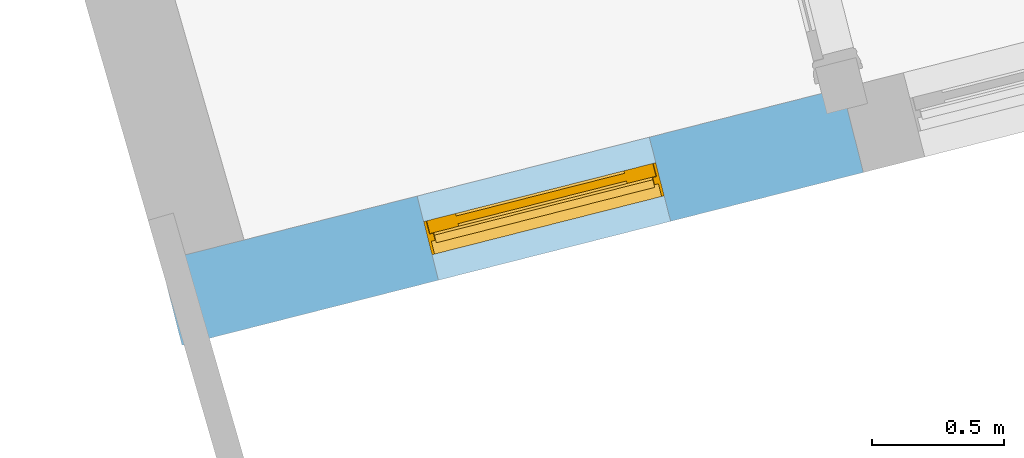
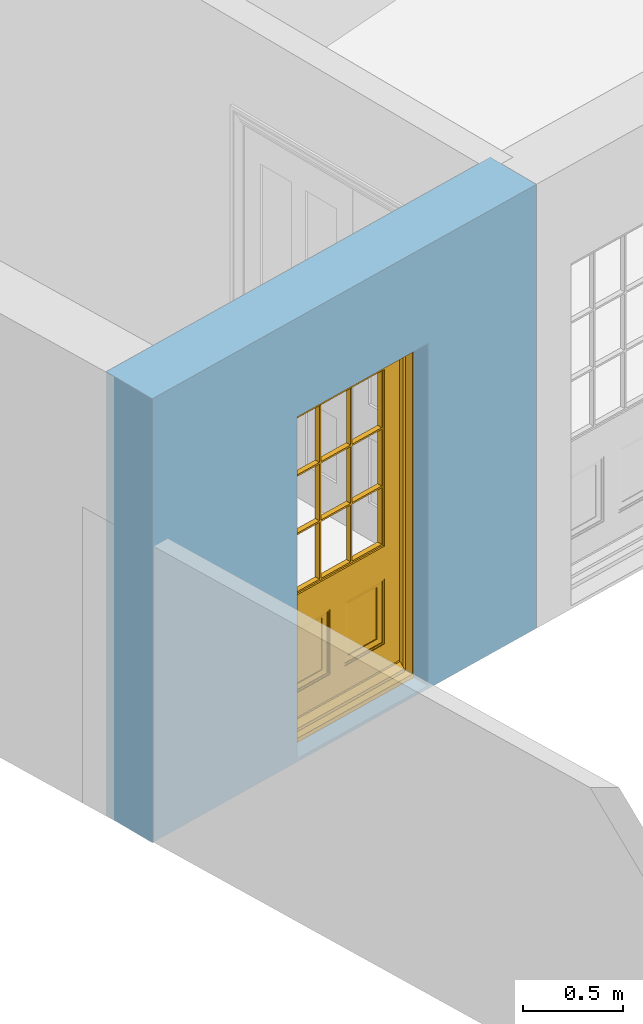
# One storey, part 2 of 15: 1 door, 1 opening, plus 1 element that does not belong to this part.
"""IFC2X3 building model written with IfcOpenShell, lengths in metres."""

import ifcopenshell
import ifcopenshell.guid

model = None  # the IFC model being written
_history = None  # IfcOwnerHistory: only IFC2X3 demands one
_inside = {}  # id of a spatial element -> (the spatial element, [elements in it])
_under = {}  # id of a project, library or spatial element -> (it, [spatial elements below it])
_declared = {}  # id of a project -> (the project, [libraries it declares])
_typed = {}  # id of a type object -> (the type object, [elements of that type])
_made_of = {}  # id of a material, layer set ... -> (it, [elements and type objects made of it])


def new_model(schema):
    """Start an empty IFC model of exactly this schema.

    Asked for "IFC4X3", IfcOpenShell would pick the latest addendum, in which some entities
    have other attributes; the version numbers below select the first issue.
    IFC2X3 requires an IfcOwnerHistory on every rooted entity: one is made here for all.
    """
    global model, _history
    if schema == "IFC4X3":
        model = ifcopenshell.file(schema_version=(4, 3, 0, 0))
    else:
        model = ifcopenshell.file(schema=schema)
    _inside.clear()
    _under.clear()
    _declared.clear()
    _typed.clear()
    _made_of.clear()
    _history = None
    if model.schema == "IFC2X3":
        org = make("IfcOrganization", Name="unknown")
        user = make(
            "IfcPersonAndOrganization",
            ThePerson=make("IfcPerson", FamilyName="unknown"),
            TheOrganization=org,
        )
        app = make(
            "IfcApplication",
            ApplicationDeveloper=org,
            Version="unknown",
            ApplicationFullName="unknown",
            ApplicationIdentifier="unknown",
        )
        _history = make(
            "IfcOwnerHistory",
            OwningUser=user,
            OwningApplication=app,
            ChangeAction="ADDED",
            CreationDate=0,
        )
    return model


def make(cls, **values):
    """One entity of the class cls with the attributes given. An attribute that is None is left unset."""
    return model.create_entity(
        cls, **{name: value for name, value in values.items() if value is not None}
    )


def rooted(cls, **values):
    """An entity with a GlobalId (a new one), such as an element, a storey or a relation."""
    return make(cls, GlobalId=ifcopenshell.guid.new(), OwnerHistory=_history, **values)


def si_unit(unit_type, name, prefix=None):
    """IfcSIUnit, for example si_unit("LENGTHUNIT", "METRE", prefix="MILLI")."""
    return make("IfcSIUnit", UnitType=unit_type, Prefix=prefix, Name=name)


def assignment(units):
    """IfcUnitAssignment: the units of a project."""
    return None if units is None else make("IfcUnitAssignment", Units=units)


def point(xyz):
    """IfcCartesianPoint."""
    return None if xyz is None else make("IfcCartesianPoint", Coordinates=xyz)


def direction(xyz):
    """IfcDirection."""
    return None if xyz is None else make("IfcDirection", DirectionRatios=xyz)


def frame(location, z_axis=None, x_axis=None):
    """IfcAxis2Placement3D, a coordinate frame: its origin and axes. An axis left out is left unset."""
    return make(
        "IfcAxis2Placement3D",
        Location=point(location),
        Axis=direction(z_axis),
        RefDirection=direction(x_axis),
    )


def origin():
    """The frame at (0, 0, 0) with its axes left unset."""
    return frame((0.0, 0.0, 0.0))


def place(relative_to, where):
    """IfcLocalPlacement: puts the frame where relative to a parent placement (None: the world)."""
    return make(
        "IfcLocalPlacement", PlacementRelTo=relative_to, RelativePlacement=where
    )


def context(
    kind, dimensions, precision=None, world=None, true_north=None, identifier=None
):
    """IfcGeometricRepresentationContext, for example the 3D "Model" context."""
    return make(
        "IfcGeometricRepresentationContext",
        ContextIdentifier=identifier,
        ContextType=kind,
        CoordinateSpaceDimension=dimensions,
        Precision=precision,
        WorldCoordinateSystem=world,
        TrueNorth=true_north,
    )


def subcontext(parent, identifier, kind, view, scale=None):
    """IfcGeometricRepresentationSubContext, for example "Body" below "Model"."""
    return make(
        "IfcGeometricRepresentationSubContext",
        ContextIdentifier=identifier,
        ContextType=kind,
        ParentContext=parent,
        TargetScale=scale,
        TargetView=view,
    )


def project(units=None, contexts=None):
    """IfcProject with its units and contexts."""
    return rooted(
        "IfcProject",
        Name="project",
        RepresentationContexts=contexts,
        UnitsInContext=assignment(units),
    )


def spatial(cls, under=None, at=None, **own):
    """A site, building, storey or space (cls), placed at a placement, below another one or the project."""
    s = rooted(cls, ObjectPlacement=at, **own)
    if under is not None:
        _under.setdefault(under.id(), (under, []))[1].append(s)
    return s


def polyline(points):
    """IfcPolyline through the points."""
    return make("IfcPolyline", Points=[point(p) for p in points])


def outline(outer, holes=None, kind="AREA"):
    """IfcArbitraryClosedProfileDef: a profile drawn as a closed curve; with holes, ...WithVoids."""
    if holes is None:
        return make("IfcArbitraryClosedProfileDef", ProfileType=kind, OuterCurve=outer)
    return make(
        "IfcArbitraryProfileDefWithVoids",
        ProfileType=kind,
        OuterCurve=outer,
        InnerCurves=holes,
    )


def extrude(swept, where, along, depth):
    """IfcExtrudedAreaSolid: the profile swept, set in the frame where, extruded along a direction by depth."""
    return make(
        "IfcExtrudedAreaSolid",
        SweptArea=swept,
        Position=where,
        ExtrudedDirection=direction(along),
        Depth=depth,
    )


def faces_of(points, faces, orient=None, outer=None):
    """IfcFace entities. A face is a list of loops; a loop is a list of indices into points, from 0.

    orient and outer hold one flag for each loop. By default every Orientation is true, the
    first loop of a face is its IfcFaceOuterBound and the others are IfcFaceBound.
    """
    made = []
    for i, loops in enumerate(faces):
        bounds = []
        for j, loop in enumerate(loops):
            is_outer = j == 0 if outer is None else outer[i][j]
            bounds.append(
                make(
                    "IfcFaceOuterBound" if is_outer else "IfcFaceBound",
                    Bound=make("IfcPolyLoop", Polygon=[points[k] for k in loop]),
                    Orientation=True if orient is None else orient[i][j],
                )
            )
        made.append(make("IfcFace", Bounds=bounds))
    return made


def faceted_brep(points, faces, orient=None, outer=None, voids=None):
    """IfcFacetedBrep: a solid bounded by flat faces; with voids (closed shells), ...WithVoids."""
    shared = [point(p) for p in points]
    hull = make("IfcClosedShell", CfsFaces=faces_of(shared, faces, orient, outer))
    if voids is None:
        return make("IfcFacetedBrep", Outer=hull)
    return make(
        "IfcFacetedBrepWithVoids",
        Outer=hull,
        Voids=[
            make(cls, CfsFaces=faces_of(shared, fs, o, b)) for cls, fs, o, b in voids
        ],
    )


def shape(context_of_items, identifier, shape_type, items):
    """IfcShapeRepresentation: the items that make up one representation, for example the "Body"."""
    return make(
        "IfcShapeRepresentation",
        ContextOfItems=context_of_items,
        RepresentationIdentifier=identifier,
        RepresentationType=shape_type,
        Items=items,
    )


def material(Name=None, Category=None):
    """IfcMaterial."""
    return make("IfcMaterial", Name=Name, Category=Category)


def layer(
    of_material, thickness, ventilated=None, Name=None, Category=None, Priority=None
):
    """IfcMaterialLayer: one layer of a wall or slab, of a material (None: an air gap)."""
    return make(
        "IfcMaterialLayer",
        Material=of_material,
        LayerThickness=thickness,
        IsVentilated=ventilated,
        Name=Name,
        Category=Category,
        Priority=Priority,
    )


def layer_set(layers, Name=None):
    """IfcMaterialLayerSet."""
    return make("IfcMaterialLayerSet", MaterialLayers=layers, LayerSetName=Name)


def layer_usage(for_layer_set, set_direction, sense, offset, extent=None):
    """IfcMaterialLayerSetUsage: how a layer set lies in its element."""
    return make(
        "IfcMaterialLayerSetUsage",
        ForLayerSet=for_layer_set,
        LayerSetDirection=set_direction,
        DirectionSense=sense,
        OffsetFromReferenceLine=offset,
        ReferenceExtent=extent,
    )


def made_of(thing, what):
    """Note that an element or type object is made of a material, layer set ...; save() writes the relation."""
    if what is not None:
        _made_of.setdefault(what.id(), (what, []))[1].append(thing)
    return thing


def element(
    cls,
    number,
    at=None,
    inside=None,
    cuts=None,
    type_object=None,
    material=None,
    context=None,
    identifier="Body",
    shape_type=None,
    held_by="IfcProductDefinitionShape",
    body=None,
    shapes=None,
    **own,
):
    """One element of the class cls, such as IfcWall. Its Tag is "e" and its number.

    at: its placement. inside: the storey or other place that contains it. cuts: it is an
    opening in that element (IfcRelVoidsElement). A single representation is given by context,
    identifier, shape_type and body (its items); several are given by shapes. held_by: the class
    of the entity that holds the representations. save() writes the other relations.
    """
    e = rooted(cls, Tag="e%d" % number, ObjectPlacement=at, **own)
    if body is not None:
        shapes = [shape(context, identifier, shape_type, body)]
    if shapes is not None:
        e.Representation = make(held_by, Representations=shapes)
    if inside is not None:
        _inside.setdefault(inside.id(), (inside, []))[1].append(e)
    if cuts is not None:
        rooted(
            "IfcRelVoidsElement", RelatingBuildingElement=cuts, RelatedOpeningElement=e
        )
    if type_object is not None:
        _typed.setdefault(type_object.id(), (type_object, []))[1].append(e)
    return made_of(e, material)


def fill(opening, filler):
    """IfcRelFillsElement: the door or window that sits in an opening."""
    return rooted(
        "IfcRelFillsElement",
        RelatingOpeningElement=opening,
        RelatedBuildingElement=filler,
    )


def aggregate(whole, parts):
    """IfcRelAggregates: a whole, such as a stair, and the parts it consists of."""
    return rooted("IfcRelAggregates", RelatingObject=whole, RelatedObjects=parts)


def save(model, path):
    """Write the relations noted so far, then the file.

    IfcRelAggregates (storeys below a building ...), IfcRelContainedInSpatialStructure (elements
    in a storey), IfcRelDefinesByType, IfcRelAssociatesMaterial and IfcRelDeclares: one each for
    every whole, place, type object, material and project.
    """
    for whole, parts in _under.values():
        aggregate(whole, parts)
    for where, things in _inside.values():
        rooted(
            "IfcRelContainedInSpatialStructure",
            RelatedElements=things,
            RelatingStructure=where,
        )
    for kind, things in _typed.values():
        rooted("IfcRelDefinesByType", RelatedObjects=things, RelatingType=kind)
    for what, things in _made_of.values():
        rooted("IfcRelAssociatesMaterial", RelatedObjects=things, RelatingMaterial=what)
    for by, libraries in _declared.values():
        rooted("IfcRelDeclares", RelatingContext=by, RelatedDefinitions=libraries)
    model.write(path)


model = new_model("IFC2X3")

# Units and contexts
model_context = context("Model", 3, world=origin())
body_context = subcontext(model_context, "Body", "Model", "MODEL_VIEW")
ifc_project = project(units=[si_unit("PLANEANGLEUNIT", "RADIAN"), si_unit("MASSUNIT", "GRAM", prefix="KILO"), si_unit("FORCEUNIT", "NEWTON", prefix="KILO"), si_unit("LENGTHUNIT", "METRE")], contexts=[model_context])

# Site, building, storey
site_placement = place(None, origin())
site = spatial("IfcSite", under=ifc_project, at=site_placement, CompositionType="ELEMENT")
building_placement = place(None, origin())
building = spatial("IfcBuilding", under=site, at=building_placement, Name="Building plot-13", CompositionType="ELEMENT")
storey_placement = place(None, frame((0.0, 0.0, 4.0)))
storey = spatial("IfcBuildingStorey", under=building, at=storey_placement, Name="Floor 0", CompositionType="ELEMENT", Elevation=4.0)

# Wall, opening, door
ifc_material = material(Name="Masonry")
ifc_layer = layer(ifc_material, 0.33, ventilated=False)
ifc_layer_set = layer_set([ifc_layer], Name="My Wall")
ifc_layer_usage = layer_usage(ifc_layer_set, "AXIS2", "NEGATIVE", 0.08)
wall_placement = place(storey_placement, origin())
wall = element("IfcWallStandardCase", 1, at=wall_placement, inside=storey, material=ifc_layer_usage, Name="exterior", context=body_context, shape_type="SweptSolid", body=[
    extrude(outline(polyline([(64.1602540157798, 43.2359589291926), (64.2413822701456, 42.9160867573121), (66.8302893451402, 43.5727037755256), (66.7491610907744, 43.8925759474061), (64.1602540157798, 43.2359589291926)])), origin(), (0.0, 0.0, 1.0), 2.7),
])
opening_placement = place(storey_placement, frame((0.0, 0.0, 0.0199999999999996)))
opening = element("IfcOpeningElement", 2, at=opening_placement, cuts=wall, Name="Opening", ObjectType="Opening", context=body_context, shape_type="SweptSolid", body=[
    extrude(outline(polyline([(65.2159636357624, 43.163267012053), (66.0980353824632, 43.3869843195467), (66.0169071280974, 43.7068564914272), (65.1348353813966, 43.4831391839336), (65.2159636357624, 43.163267012053)])), origin(), (0.0, 0.0, 1.0), 2.08),
])
door_placement = place(storey_placement, frame((65.1545028370004, 43.4055944149928, 0.0199999999999996), z_axis=(0.0, 0.0, 1.0), x_axis=(0.882071746700788, 0.223717307493644, 0.0)))
door = element("IfcDoor", 3, at=door_placement, inside=storey, Name="kitchen outside door", OverallHeight=2.08, OverallWidth=0.91, context=body_context, shape_type="Brep", held_by="IfcProductRepresentation", body=[
    faceted_brep([(0.545, -0.055, 0.265), (0.745, -0.055, 0.265), (0.745, -0.05, 0.265), (0.545, -0.05, 0.265), (0.745, -0.05, 0.58), (0.545, -0.05, 0.58), (0.545, -0.055, 0.58), (0.515, -0.06, 0.235), (0.775, -0.06, 0.235), (0.745, -0.055, 0.58), (0.515, -0.06, 0.61), (0.515, -0.065, 0.235), (0.775, -0.065, 0.235), (0.775, -0.06, 0.61), (0.515, -0.065, 0.61), (0.785, -0.065, 0.225), (0.505, -0.065, 0.225), (0.775, -0.065, 0.61), (0.505, -0.065, 0.62), (0.785, -0.065, 0.62), (0.505, -0.07, 0.225), (0.785, -0.07, 0.225), (0.505, -0.07, 0.62), (0.785, -0.07, 0.62), (0.883, -0.07, 0.075), (0.898, -0.07, 0.075), (0.405, -0.07, 0.62), (0.405, -0.07, 0.225), (0.027, -0.07, 0.075), (0.785, -0.07, 0.82), (0.125, -0.07, 0.82), (0.405, -0.065, 0.62), (0.405, -0.065, 0.225), (0.898, -0.07, 2.068), (0.027, -0.08, 0.075), (0.883, -0.08, 0.075), (0.125, -0.07, 0.225), (0.012, -0.07, 0.075), (0.785, -0.06, 0.82), (0.125, -0.06, 0.82), (0.125, -0.07, 0.62), (0.125, -0.065, 0.62), (0.395, -0.065, 0.61), (0.395, -0.065, 0.235), (0.125, -0.065, 0.225), (0.785, -0.07, 1.895), (0.027, -0.11, 0.045), (0.883, -0.11, 0.045), (0.558333, -0.06, 0.83), (0.351667, -0.06, 0.83), (0.125, -0.07, 1.895), (0.125, -0.06, 1.895), (0.785, -0.06, 1.895), (0.012, -0.07, 2.068), (0.135, -0.065, 0.61), (0.395, -0.06, 0.61), (0.395, -0.06, 0.235), (0.135, -0.065, 0.235), (0.027, -0.11, 0.027), (0.883, -0.11, 0.027), (0.568333, -0.06, 0.83), (0.558333, -0.03, 0.83), (0.351667, -0.03, 0.83), (0.341667, -0.06, 0.83), (0.135, -0.06, 1.185), (0.135, -0.06, 1.53), (0.775, -0.06, 1.53), (0.775, -0.06, 1.185), (0.135, -0.06, 0.61), (0.365, -0.055, 0.58), (0.365, -0.055, 0.265), (0.135, -0.06, 0.235), (0.568333, -0.06, 1.175), (0.558333, -0.06, 1.175), (0.775, -0.06, 0.83), (0.558333, -0.03, 1.175), (0.785, -0.03, 0.82), (0.125, -0.03, 0.82), (0.351667, -0.03, 1.175), (0.351667, -0.06, 1.175), (0.341667, -0.06, 1.175), (0.135, -0.06, 0.83), (0.135, -0.06, 1.175), (0.135, -0.03, 1.185), (0.135, -0.03, 1.53), (0.135, -0.06, 1.54), (0.351667, -0.06, 1.885), (0.558333, -0.06, 1.885), (0.775, -0.03, 1.53), (0.775, -0.03, 1.185), (0.775, -0.06, 1.175), (0.775, -0.06, 1.54), (0.165, -0.055, 0.58), (0.365, -0.05, 0.58), (0.365, -0.05, 0.265), (0.165, -0.055, 0.265), (0.568333, -0.03, 0.83), (0.568333, -0.03, 1.175), (0.568333, -0.06, 1.185), (0.558333, -0.06, 1.185), (0.775, -0.03, 0.83), (0.785, -0.02, 0.82), (0.125, -0.02, 0.82), (0.341667, -0.03, 0.83), (0.341667, -0.03, 1.175), (0.351667, -0.06, 1.185), (0.341667, -0.06, 1.185), (0.135, -0.03, 0.83), (0.341667, -0.03, 1.185), (0.125, -0.03, 1.895), (0.341667, -0.03, 1.53), (0.341667, -0.06, 1.53), (0.135, -0.06, 1.885), (0.341667, -0.06, 1.54), (0.341667, -0.06, 1.885), (0.558333, -0.03, 1.885), (0.351667, -0.03, 1.885), (0.568333, -0.06, 1.885), (0.785, -0.03, 1.895), (0.568333, -0.03, 1.185), (0.568333, -0.06, 1.53), (0.568333, -0.03, 1.53), (0.568333, -0.06, 1.54), (0.775, -0.06, 1.885), (0.165, -0.05, 0.58), (0.165, -0.05, 0.265), (0.775, -0.03, 1.175), (0.558333, -0.06, 1.53), (0.351667, -0.03, 1.185), (0.558333, -0.03, 1.185), (0.505, -0.02, 0.62), (0.405, -0.02, 0.62), (0.125, -0.02, 1.895), (0.785, -0.02, 1.895), (0.351667, -0.06, 1.53), (0.135, -0.03, 1.175), (0.135, -0.03, 1.54), (0.341667, -0.03, 1.54), (0.135, -0.03, 1.885), (0.351667, -0.06, 1.54), (0.558333, -0.03, 1.54), (0.558333, -0.06, 1.54), (0.351667, -0.03, 1.54), (0.775, -0.03, 1.54), (0.568333, -0.03, 1.54), (0.775, -0.03, 1.885), (0.558333, -0.03, 1.53), (0.405, -0.02, 0.225), (0.505, -0.02, 0.225), (0.125, -0.02, 0.62), (0.785, -0.02, 0.62), (0.012, -0.02, 2.068), (0.898, -0.02, 2.068), (0.351667, -0.03, 1.53), (0.341667, -0.03, 1.885), (0.568333, -0.03, 1.885), (0.405, -0.025, 0.225), (0.405, -0.025, 0.62), (0.505, -0.025, 0.62), (0.505, -0.025, 0.225), (0.898, -0.02, 0.027), (0.012, -0.02, 0.027), (0.125, -0.025, 0.62), (0.785, -0.025, 0.62), (0.395, -0.025, 0.235), (0.395, -0.025, 0.61), (0.125, -0.02, 0.225), (0.125, -0.025, 0.225), (0.515, -0.025, 0.61), (0.515, -0.025, 0.235), (0.785, -0.02, 0.225), (0.785, -0.025, 0.225), (0.135, -0.025, 0.61), (0.775, -0.025, 0.61), (0.135, -0.025, 0.235), (0.395, -0.03, 0.235), (0.395, -0.03, 0.61), (0.515, -0.03, 0.61), (0.515, -0.03, 0.235), (0.775, -0.025, 0.235), (0.135, -0.03, 0.61), (0.775, -0.03, 0.61), (0.135, -0.03, 0.235), (0.365, -0.035, 0.265), (0.365, -0.035, 0.58), (0.545, -0.035, 0.58), (0.545, -0.035, 0.265), (0.775, -0.03, 0.235), (0.165, -0.035, 0.58), (0.745, -0.035, 0.58), (0.165, -0.035, 0.265), (0.365, -0.04, 0.58), (0.365, -0.04, 0.265), (0.545, -0.04, 0.58), (0.545, -0.04, 0.265), (0.745, -0.035, 0.265), (0.165, -0.04, 0.58), (0.745, -0.04, 0.58), (0.165, -0.04, 0.265), (0.745, -0.04, 0.265), (0.885, -0.072, 0.025), (0.025, -0.072, 0.025), (0.025, -0.1, 0.025), (0.885, -0.1, 0.025), (0.9, -0.02, 0.025), (0.01, -0.02, 0.025), (0.9, -0.072, 0.025), (0.91, -0.02, 0.0), (0.0, -0.02, 0.0), (0.01, -0.072, 0.025), (0.9, -0.072, 2.07), (0.9, -0.02, 2.07), (0.885, -0.072, 2.055), (0.91, -0.02, 2.08), (0.01, -0.02, 2.07), (0.0, -0.02, 2.08), (0.01, -0.072, 2.07), (0.025, -0.072, 2.055), (0.0, -0.15, 2.08), (0.91, -0.15, 2.08), (0.01, -0.15, 2.07), (0.9, -0.15, 2.07), (0.01, -0.1, 2.07), (0.9, -0.1, 2.07), (0.0, -0.15, 0.0), (0.91, -0.15, 0.0), (0.01, -0.15, 0.025), (0.9, -0.15, 0.025), (0.01, -0.1, 0.025), (0.025, -0.1, 2.055), (0.9, -0.1, 0.025), (0.885, -0.1, 2.055), (0.898, -0.07, 0.027), (0.012, -0.07, 0.027), (0.883, -0.07, 0.027), (0.027, -0.07, 0.027)], [[[0, 1, 2, 3]], [[2, 4, 5, 3]], [[0, 3, 5, 6]], [[1, 0, 7, 8]], [[9, 4, 2, 1]], [[9, 6, 5, 4]], [[0, 6, 10, 7]], [[8, 7, 11, 12]], [[8, 13, 9, 1]], [[13, 10, 6, 9]], [[7, 10, 14, 11]], [[15, 12, 11, 16]], [[12, 17, 13, 8]], [[17, 14, 10, 13]], [[18, 16, 11, 14]], [[15, 19, 17, 12]], [[15, 16, 20, 21]], [[14, 17, 19, 18]], [[16, 18, 22, 20]], [[21, 23, 19, 15]], [[24, 25, 21, 20]], [[23, 22, 18, 19]], [[20, 22, 26, 27]], [[23, 21, 25]], [[28, 24, 20, 27]], [[22, 23, 29]], [[29, 30, 26, 22]], [[27, 26, 31, 32]], [[23, 25, 33, 29]], [[34, 35, 24, 28]], [[28, 27, 36, 37]], [[38, 39, 30, 29]], [[26, 30, 40]], [[26, 40, 41, 31]], [[42, 43, 32, 31]], [[32, 44, 36, 27]], [[33, 45, 29]], [[46, 47, 35, 34]], [[36, 40, 37]], [[39, 38, 48, 49]], [[50, 30, 39, 51]], [[29, 45, 52, 38]], [[53, 37, 40, 30]], [[44, 41, 40, 36]], [[31, 41, 54, 42]], [[43, 42, 55, 56]], [[57, 44, 32, 43]], [[50, 45, 33, 53]], [[47, 46, 58, 59]], [[60, 48, 38]], [[49, 48, 61, 62]], [[49, 63, 39]], [[50, 53, 30]], [[51, 39, 64, 65]], [[45, 50, 51, 52]], [[66, 67, 38, 52]], [[57, 54, 41, 44]], [[42, 54, 68, 55]], [[56, 55, 69, 70]], [[56, 71, 57, 43]], [[60, 72, 73, 48]], [[60, 38, 74]], [[48, 73, 75, 61]], [[76, 77, 62, 61]], [[62, 78, 79, 49]], [[49, 79, 80, 63]], [[63, 81, 39]], [[82, 64, 39]], [[65, 64, 83, 84]], [[85, 51, 65]], [[52, 51, 86, 87]], [[88, 89, 67, 66]], [[90, 38, 67]], [[91, 66, 52]], [[71, 68, 54, 57]], [[55, 68, 92, 69]], [[69, 93, 94, 70]], [[70, 95, 71, 56]], [[96, 97, 72, 60]], [[73, 72, 98, 99]], [[74, 38, 90]], [[100, 96, 60, 74]], [[75, 73, 79, 78]], [[61, 75, 97, 96]], [[101, 102, 77, 76]], [[77, 103, 62]], [[96, 76, 61]], [[103, 104, 78, 62]], [[80, 79, 105, 106]], [[63, 80, 104, 103]], [[81, 63, 103, 107]], [[81, 82, 39]], [[106, 64, 82, 80]], [[106, 108, 83, 64]], [[84, 83, 77, 109]], [[110, 111, 65, 84]], [[112, 51, 85]], [[113, 85, 65, 111]], [[114, 86, 51]], [[115, 87, 86, 116]], [[117, 52, 87]], [[118, 76, 89, 88]], [[119, 98, 67, 89]], [[120, 121, 88, 66]], [[67, 98, 72, 90]], [[91, 122, 120, 66]], [[91, 52, 123]], [[95, 92, 68, 71]], [[69, 92, 124, 93]], [[94, 93, 124, 125]], [[94, 125, 95, 70]], [[72, 97, 126, 90]], [[127, 99, 98, 120]], [[99, 105, 79, 73]], [[74, 90, 126, 100]], [[96, 100, 76]], [[128, 129, 75, 78]], [[97, 75, 129, 119]], [[130, 131, 102, 101]], [[109, 77, 102, 132]], [[133, 101, 76, 118]], [[77, 107, 103]], [[78, 104, 108, 128]], [[111, 106, 105, 134]], [[104, 80, 82, 135]], [[107, 135, 82, 81]], [[110, 108, 106, 111]], [[104, 135, 83, 108]], [[83, 135, 77]], [[136, 84, 109]], [[110, 84, 136, 137]], [[114, 51, 112]], [[85, 136, 138, 112]], [[113, 137, 136, 85]], [[111, 134, 139, 113]], [[86, 114, 113, 139]], [[140, 141, 87, 115]], [[139, 142, 116, 86]], [[109, 118, 115, 116]], [[117, 123, 52]], [[117, 87, 141, 122]], [[126, 89, 76]], [[143, 118, 88]], [[120, 98, 119, 121]], [[119, 89, 126, 97]], [[144, 143, 88, 121]], [[144, 122, 91, 143]], [[127, 120, 122, 141]], [[143, 91, 123, 145]], [[124, 92, 95, 125]], [[146, 129, 99, 127]], [[99, 129, 128, 105]], [[100, 126, 76]], [[121, 119, 129, 146]], [[147, 131, 130, 148]], [[131, 149, 102]], [[130, 101, 150]], [[102, 151, 132]], [[118, 109, 132, 133]], [[101, 133, 152]], [[107, 77, 135]], [[153, 128, 108, 110]], [[134, 105, 128, 153]], [[109, 138, 136]], [[153, 110, 137, 142]], [[154, 114, 112, 138]], [[137, 113, 114, 154]], [[141, 139, 134, 127]], [[141, 140, 142, 139]], [[144, 140, 115, 155]], [[142, 137, 154, 116]], [[155, 115, 118]], [[116, 154, 109]], [[117, 155, 145, 123]], [[122, 144, 155, 117]], [[143, 145, 118]], [[121, 146, 140, 144]], [[146, 127, 134, 153]], [[156, 157, 131, 147]], [[148, 130, 158, 159]], [[148, 160, 161, 147]], [[157, 162, 149, 131]], [[161, 151, 102, 149]], [[101, 152, 160, 150]], [[163, 158, 130, 150]], [[151, 152, 133, 132]], [[154, 138, 109]], [[142, 140, 146, 153]], [[145, 155, 118]], [[157, 156, 164, 165]], [[147, 166, 167, 156]], [[168, 169, 159, 158]], [[170, 148, 159, 171]], [[148, 170, 160]], [[166, 147, 161]], [[172, 162, 157, 165]], [[166, 149, 162, 167]], [[166, 161, 149]], [[150, 160, 170]], [[163, 173, 168, 158]], [[171, 163, 150, 170]], [[174, 164, 156, 167]], [[175, 176, 165, 164]], [[169, 168, 177, 178]], [[171, 159, 169, 179]], [[167, 162, 172, 174]], [[176, 180, 172, 165]], [[179, 173, 163, 171]], [[181, 177, 168, 173]], [[164, 174, 182, 175]], [[183, 184, 176, 175]], [[178, 177, 185, 186]], [[179, 169, 178, 187]], [[174, 172, 180, 182]], [[184, 188, 180, 176]], [[187, 181, 173, 179]], [[189, 185, 177, 181]], [[175, 182, 190, 183]], [[191, 184, 183, 192]], [[185, 193, 194, 186]], [[187, 178, 186, 195]], [[182, 180, 188, 190]], [[191, 196, 188, 184]], [[195, 189, 181, 187]], [[197, 193, 185, 189]], [[183, 190, 198, 192]], [[198, 196, 191, 192]], [[194, 193, 197, 199]], [[195, 186, 194, 199]], [[188, 196, 198, 190]], [[197, 189, 195, 199]], [[200, 201, 202, 203]], [[201, 200, 204, 205]], [[206, 204, 200]], [[204, 207, 208, 205]], [[209, 201, 205]], [[210, 211, 204, 206]], [[206, 200, 212, 210]], [[211, 213, 207, 204]], [[214, 205, 208, 215]], [[216, 217, 201, 209]], [[205, 214, 216, 209]], [[216, 214, 211, 210]], [[210, 212, 217, 216]], [[214, 215, 213, 211]], [[218, 219, 213, 215]], [[219, 218, 220, 221]], [[221, 220, 222, 223]], [[215, 208, 224, 218]], [[225, 224, 208, 207]], [[224, 226, 220, 218]], [[224, 225, 227, 226]], [[219, 225, 207, 213]], [[228, 222, 220, 226]], [[219, 221, 227, 225]], [[226, 227, 203, 202]], [[202, 229, 222, 228]], [[228, 226, 202]], [[227, 221, 223, 230]], [[230, 203, 227]], [[217, 229, 202, 201]], [[231, 223, 222, 229]], [[230, 223, 231, 203]], [[231, 229, 217, 212]], [[212, 200, 203, 231]], [[33, 152, 151, 53]], [[25, 160, 152, 33]], [[161, 37, 53, 151]], [[232, 160, 25]], [[161, 233, 37]], [[160, 232, 234]], [[24, 234, 232, 25]], [[233, 161, 235]], [[37, 233, 235, 28]], [[161, 160, 234, 235]], [[35, 47, 234, 24]], [[28, 235, 46, 34]], [[58, 235, 234, 59]], [[59, 234, 47]], [[58, 46, 235]]]),
])
fill(opening, door)

save(model, "model.ifc")
